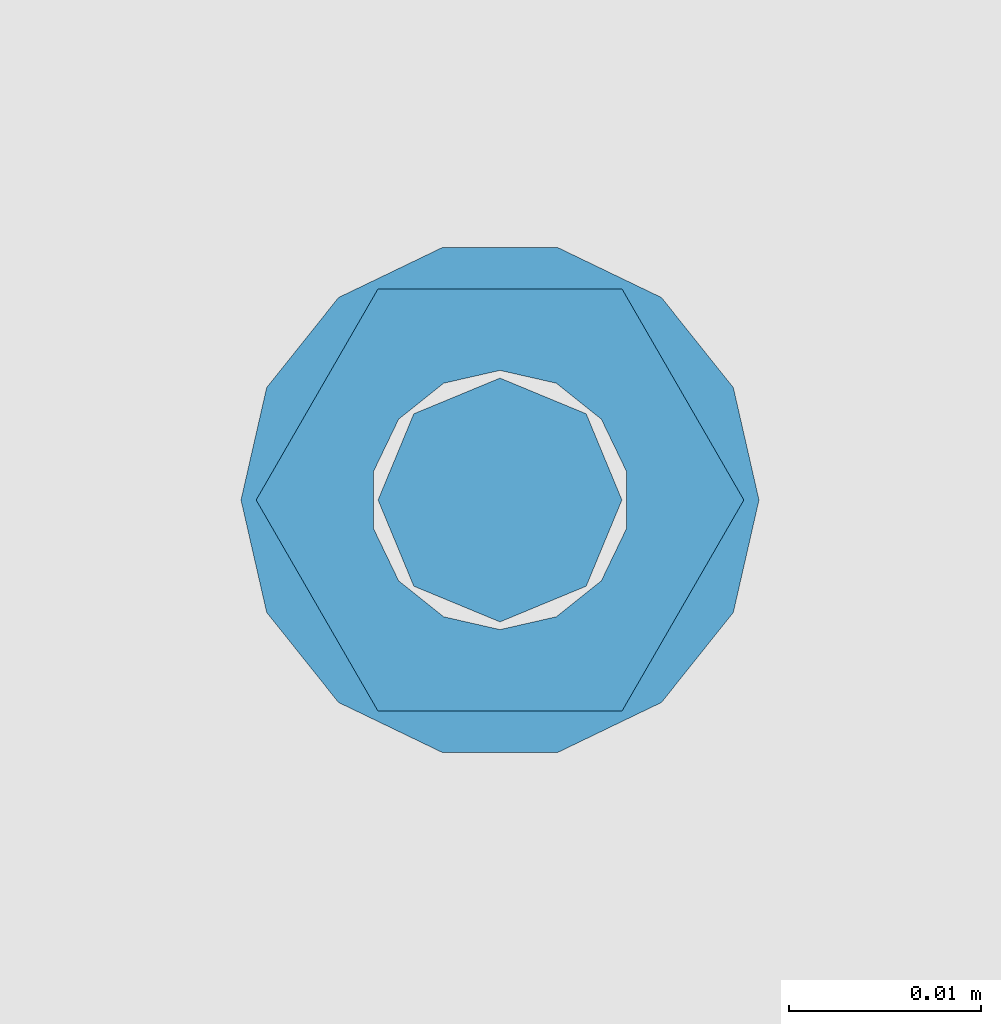
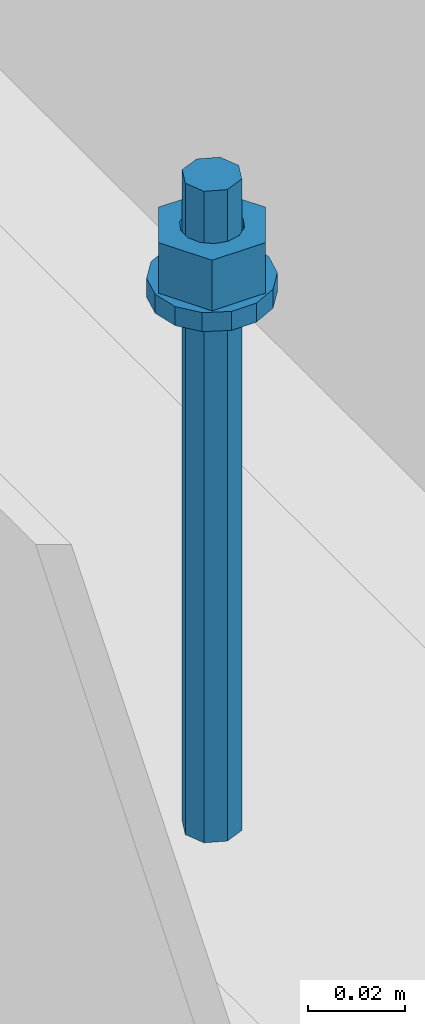
# One storey, part 543 of 1179: 1 column, 1 element without a shape of its own.
"""IFC2X3 building model written with IfcOpenShell, lengths in millimetres."""

from ifc_helpers import new_model, si_unit, frame, origin_with_axes, place, context, subcontext, project, spatial, faceted_brep, material, type_object, element, aggregate, save


model = new_model("IFC2X3")

# Units and contexts
model_context = context("Model", 3, precision=1e-05, world=origin_with_axes())
body_context = subcontext(model_context, "Body", "Model", "MODEL_VIEW")
ifc_project = project(units=[si_unit("LENGTHUNIT", "METRE", prefix="MILLI"), si_unit("AREAUNIT", "SQUARE_METRE"), si_unit("VOLUMEUNIT", "CUBIC_METRE"), si_unit("MASSUNIT", "GRAM", prefix="KILO"), si_unit("TIMEUNIT", "SECOND"), si_unit("PLANEANGLEUNIT", "RADIAN"), si_unit("SOLIDANGLEUNIT", "STERADIAN"), si_unit("THERMODYNAMICTEMPERATUREUNIT", "DEGREE_CELSIUS"), si_unit("LUMINOUSINTENSITYUNIT", "LUMEN")], contexts=[model_context])

# Site, building, storey
site_placement = place(None, origin_with_axes())
site = spatial("IfcSite", under=ifc_project, at=site_placement, CompositionType="ELEMENT")
building_placement = place(site_placement, origin_with_axes())
building = spatial("IfcBuilding", under=site, at=building_placement, Name="Undefined", CompositionType="ELEMENT")
storey_placement = place(building_placement, origin_with_axes())
storey = spatial("IfcBuildingStorey", under=building, at=storey_placement, Name="Undefined", CompositionType="ELEMENT", Elevation=0.0)

# Assembly, column
assembly_placement = place(storey_placement, origin_with_axes())
assembly = element("IfcElementAssembly", 1, at=assembly_placement, inside=storey, Name="BEAM", AssemblyPlace="NOTDEFINED", PredefinedType="RIGID_FRAME")
ifc_material = material(Name="STEEL/A307")
column_type = type_object("IfcColumnType", PredefinedType="NOTDEFINED")
column_placement = place(assembly_placement, frame((14185.904525842, 37129.2528445907, 4102.1), z_axis=(0.0, 1.0, 0.0), x_axis=(0.0, 0.0, 1.0)))
column = element("IfcColumn", 2, at=column_placement, type_object=column_type, material=ifc_material, Name="THREADED ROD", context=body_context, shape_type="Brep", body=[
    faceted_brep([(0.0, -4.49012806053361, 4.49012806053452), (0.0, -6.34999999999854, 0.0), (163.512500000001, -6.34999999999854, 0.0), (163.512500000001, -4.49012806053361, 4.49012806053452), (0.0, 0.0, 6.34999999999991), (0.0, 4.49012806053361, 4.49012806053452), (0.0, 6.34999999999854, 0.0), (0.0, 4.49012806053361, -4.49012806053452), (0.0, 0.0, -6.34999999999991), (0.0, -4.49012806053361, -4.49012806053452), (163.512500000001, 0.0, 6.35000000000036), (163.512500000001, 4.49012806053361, 4.49012806053452), (163.512500000001, 6.34999999999854, 0.0), (163.512500000001, 4.49012806053361, -4.49012806053452), (163.512500000001, 0.0, -6.35000000000036), (163.512500000001, -4.49012806053361, -4.49012806053452), (133.349999999999, -12.1540698217887, -5.85309154138668), (133.349999999999, -8.41087728436833, -10.5469065195502), (138.112499999999, -8.41087728436833, -10.5469065195502), (138.112499999999, -12.1540698217887, -5.85309154138668), (133.349999999999, -3.00180734814057, -13.1517773121886), (138.112499999999, -3.00180734814057, -13.1517773121886), (133.349999999999, 3.00180734814057, -13.1517773121886), (138.112499999999, 3.00180734814057, -13.1517773121886), (133.349999999999, 8.41087728436833, -10.5469065195502), (138.112499999999, 8.41087728436833, -10.5469065195502), (133.349999999999, 12.1540698217887, -5.85309154138668), (138.112499999999, 12.1540698217887, -5.85309154138668), (133.349999999999, 13.4899997711182, 0.0), (138.112499999999, 13.4899997711182, 0.0), (133.349999999999, 12.1540698217887, 5.85309154138668), (138.112499999999, 12.1540698217887, 5.85309154138668), (133.349999999999, 8.41087728436833, 10.5469065195502), (138.112499999999, 8.41087728436833, 10.5469065195502), (133.349999999999, 3.00180734814057, 13.1517773121886), (138.112499999999, 3.00180734814057, 13.1517773121886), (133.349999999999, -3.00180734814057, 13.1517773121886), (138.112499999999, -3.00180734814057, 13.1517773121886), (133.349999999999, -8.41087728436833, 10.5469065195502), (138.112499999999, -8.41087728436833, 10.5469065195502), (133.349999999999, -12.1540698217887, 5.85309154138668), (138.112499999999, -12.1540698217887, 5.85309154138668), (133.349999999999, -13.4899997711182, 0.0), (138.112499999999, -13.4899997711182, 0.0), (138.112499999999, -12.6999998092651, 0.0), (138.112499999999, -6.34999990463257, 11.0), (138.112499999999, 6.34999990463257, 11.0), (138.112499999999, 12.6999998092651, 0.0), (138.112499999999, 6.34999990463257, -11.0), (138.112499999999, -6.34999990463257, -11.0), (133.349999999999, -2.92871523904432, 6.0815398583436), (133.349999999999, -5.27736250665839, 4.20855616254994), (133.349999999999, -6.58076340722801, 1.50201630420634), (133.349999999999, -6.58076340722801, -1.50201630420634), (133.349999999999, -5.27736250665839, -4.20855616254994), (133.349999999999, -2.92871523904432, -6.0815398583436), (133.349999999999, 0.0, -6.75), (133.349999999999, 2.92871523904432, -6.0815398583436), (133.349999999999, 5.27736250665839, -4.20855616254994), (133.349999999999, 6.58076340722801, -1.50201630420634), (133.349999999999, 6.58076340722801, 1.50201630420634), (133.349999999999, 5.27736250665839, 4.20855616254994), (133.349999999999, 2.92871523904432, 6.0815398583436), (133.349999999999, 0.0, 6.75), (150.812499999999, -2.92871523904432, 6.0815398583436), (150.812499999999, 0.0, 6.75), (150.812499999999, -5.27736250665839, 4.20855616254994), (150.812499999999, -6.58076340722801, 1.50201630420634), (150.812499999999, -5.27736250665839, -4.20855616254994), (150.812499999999, -6.58076340722801, -1.50201630420634), (150.812499999999, -2.92871523904432, -6.0815398583436), (150.812499999999, 0.0, -6.75), (150.812499999999, 2.92871523904432, -6.0815398583436), (150.812499999999, 5.27736250665839, -4.20855616254994), (150.812499999999, 6.58076340722801, -1.50201630420634), (150.812499999999, 5.27736250665839, 4.20855616254994), (150.812499999999, 6.58076340722801, 1.50201630420634), (150.812499999999, 2.92871523904432, 6.0815398583436), (150.812499999999, -12.6999998092651, 0.0), (150.812499999999, -6.34999990463257, 11.0), (150.812499999999, 6.34999990463257, -11.0), (150.812499999999, -6.34999990463257, -11.0), (150.812499999999, 12.6999998092651, 0.0), (150.812499999999, 6.34999990463257, 11.0)], [[[0, 1, 2, 3]], [[0, 4, 5, 6, 7, 8, 9, 1]], [[5, 4, 10, 11]], [[6, 5, 11, 12]], [[7, 6, 12, 13]], [[8, 7, 13, 14]], [[9, 8, 14, 15]], [[1, 9, 15, 2]], [[14, 13, 12, 11, 10, 3, 2, 15]], [[4, 0, 3, 10]], [[16, 17, 18, 19]], [[17, 20, 21, 18]], [[20, 22, 23, 21]], [[22, 24, 25, 23]], [[24, 26, 27, 25]], [[26, 28, 29, 27]], [[28, 30, 31, 29]], [[30, 32, 33, 31]], [[32, 34, 35, 33]], [[34, 36, 37, 35]], [[36, 38, 39, 37]], [[38, 40, 41, 39]], [[40, 42, 43, 41]], [[18, 21, 23, 25, 27, 29, 31, 33, 35, 37, 39, 41, 43, 19], [44, 45, 46, 47, 48, 49]], [[42, 16, 19, 43]], [[40, 38, 36, 34, 32, 30, 28, 26, 24, 22, 20, 17, 16, 42], [50, 51, 52, 53, 54, 55, 56, 57, 58, 59, 60, 61, 62, 63]], [[64, 50, 63, 65]], [[66, 51, 50, 64]], [[67, 52, 51, 66]], [[68, 54, 53, 69]], [[70, 55, 54, 68]], [[71, 56, 55, 70]], [[72, 57, 56, 71]], [[73, 58, 57, 72]], [[74, 59, 58, 73]], [[75, 61, 60, 76]], [[77, 62, 61, 75]], [[77, 65, 63, 62]], [[78, 79, 45, 44]], [[80, 81, 49, 48]], [[82, 80, 48, 47]], [[83, 82, 47, 46]], [[79, 83, 46, 45]], [[81, 78, 44, 49]], [[53, 52, 67, 69]], [[60, 59, 74, 76]], [[80, 82, 83, 79, 78, 81], [75, 76, 74, 73, 72, 71, 70, 68, 69, 67, 66, 64, 65, 77]]]),
])
aggregate(assembly, [column])

save(model, "model.ifc")
